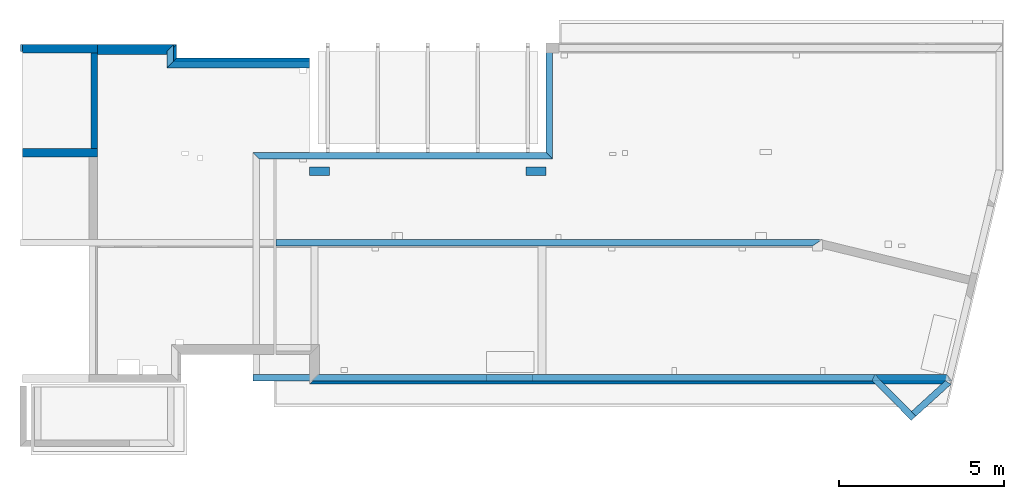
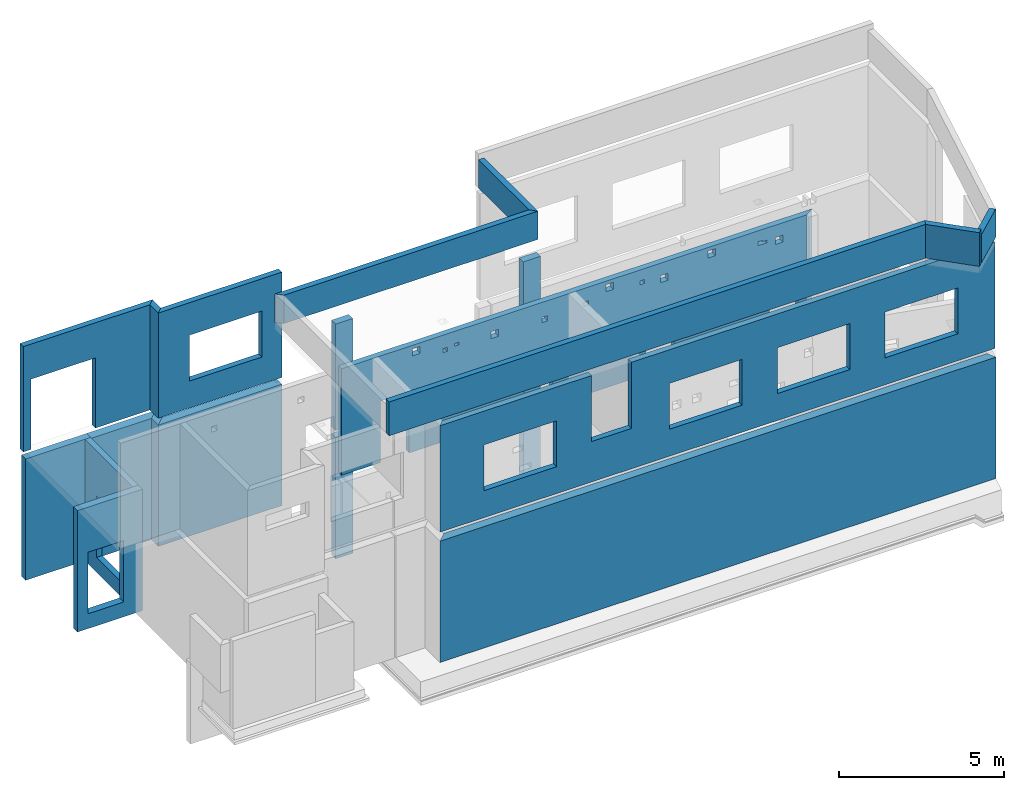
# One storey, part 3 of 7: 21 walls, 28 openings.
"""IFC2X3 building model written with IfcOpenShell, lengths in millimetres."""

from ifc_helpers import new_model, entity, si_unit, converted_unit, derived_unit, money_unit, direction, frame, frame_2d, origin_with_axes, place, context, subcontext, project, spatial, polyline, rectangle, outline, extrude, material, layer, layer_set, layer_usage, type_object, element, save


model = new_model("IFC2X3")

# Units and contexts
model_context = context("Model", 3, precision=1e-05, world=origin_with_axes(), true_north=direction((0.0, 1.0)))
body_context = subcontext(model_context, "Body", "Model", "MODEL_VIEW", scale=1.0)
ifc_project = project(units=[si_unit("LENGTHUNIT", "METRE", prefix="MILLI"), si_unit("AREAUNIT", "SQUARE_METRE"), si_unit("VOLUMEUNIT", "CUBIC_METRE"), si_unit("ABSORBEDDOSEUNIT", "GRAY"), si_unit("AMOUNTOFSUBSTANCEUNIT", "MOLE"), si_unit("DOSEEQUIVALENTUNIT", "SIEVERT"), si_unit("ELECTRICCAPACITANCEUNIT", "FARAD"), si_unit("ELECTRICCHARGEUNIT", "COULOMB"), si_unit("ELECTRICCONDUCTANCEUNIT", "SIEMENS"), si_unit("ELECTRICCURRENTUNIT", "AMPERE"), si_unit("ELECTRICRESISTANCEUNIT", "OHM"), si_unit("ELECTRICVOLTAGEUNIT", "VOLT"), si_unit("ENERGYUNIT", "JOULE"), si_unit("FORCEUNIT", "NEWTON"), si_unit("FREQUENCYUNIT", "HERTZ"), si_unit("ILLUMINANCEUNIT", "LUX"), si_unit("INDUCTANCEUNIT", "HENRY"), si_unit("LUMINOUSFLUXUNIT", "LUMEN"), si_unit("LUMINOUSINTENSITYUNIT", "CANDELA"), si_unit("MAGNETICFLUXDENSITYUNIT", "TESLA"), si_unit("MAGNETICFLUXUNIT", "WEBER"), si_unit("MASSUNIT", "GRAM"), converted_unit("PLANEANGLEUNIT", "degree", entity("IfcReal", 0.0174532925199433), si_unit("PLANEANGLEUNIT", "RADIAN"), dimensions=[0, 0, 0, 0, 0, 0, 0]), si_unit("POWERUNIT", "WATT"), si_unit("PRESSUREUNIT", "PASCAL"), si_unit("RADIOACTIVITYUNIT", "BECQUEREL"), si_unit("SOLIDANGLEUNIT", "STERADIAN"), si_unit("THERMODYNAMICTEMPERATUREUNIT", "KELVIN"), si_unit("TIMEUNIT", "SECOND"), derived_unit("ACCELERATIONUNIT", [(si_unit("LENGTHUNIT", "METRE", prefix="MILLI"), 1), (si_unit("TIMEUNIT", "SECOND"), -2)]), derived_unit("ANGULARVELOCITYUNIT", [(converted_unit("PLANEANGLEUNIT", "degree", entity("IfcReal", 0.0174532925199433), si_unit("PLANEANGLEUNIT", "RADIAN"), dimensions=[0, 0, 0, 0, 0, 0, 0]), 1), (si_unit("TIMEUNIT", "SECOND"), -1)]), derived_unit("CURVATUREUNIT", [(converted_unit("PLANEANGLEUNIT", "degree", entity("IfcReal", 0.0174532925199433), si_unit("PLANEANGLEUNIT", "RADIAN"), dimensions=[0, 0, 0, 0, 0, 0, 0]), 1), (si_unit("LENGTHUNIT", "METRE", prefix="MILLI"), -1)]), derived_unit("DYNAMICVISCOSITYUNIT", [(si_unit("PRESSUREUNIT", "PASCAL"), 1), (si_unit("TIMEUNIT", "SECOND"), 1)]), derived_unit("HEATFLUXDENSITYUNIT", [(si_unit("POWERUNIT", "WATT"), 1), (si_unit("LENGTHUNIT", "METRE", prefix="MILLI"), -2)]), derived_unit("HEATINGVALUEUNIT", [(si_unit("ENERGYUNIT", "JOULE"), 1), (si_unit("MASSUNIT", "GRAM"), -1)]), derived_unit("INTEGERCOUNTRATEUNIT", [(si_unit("TIMEUNIT", "SECOND"), -1)]), derived_unit("IONCONCENTRATIONUNIT", [(si_unit("MASSUNIT", "GRAM"), 1), (si_unit("VOLUMEUNIT", "CUBIC_METRE"), -1)]), derived_unit("ISOTHERMALMOISTURECAPACITYUNIT", [(si_unit("VOLUMEUNIT", "CUBIC_METRE"), 1), (si_unit("MASSUNIT", "GRAM"), -1)]), derived_unit("KINEMATICVISCOSITYUNIT", [(si_unit("AREAUNIT", "SQUARE_METRE"), 1), (si_unit("TIMEUNIT", "SECOND"), -1)]), derived_unit("LINEARFORCEUNIT", [(si_unit("FORCEUNIT", "NEWTON"), 1), (si_unit("LENGTHUNIT", "METRE", prefix="MILLI"), -1)]), derived_unit("LINEARMOMENTUNIT", [(si_unit("FORCEUNIT", "NEWTON"), 1), (si_unit("LENGTHUNIT", "METRE", prefix="MILLI"), -1)]), derived_unit("LINEARSTIFFNESSUNIT", [(si_unit("FORCEUNIT", "NEWTON"), 1), (si_unit("LENGTHUNIT", "METRE", prefix="MILLI"), -1)]), derived_unit("LINEARVELOCITYUNIT", [(si_unit("LENGTHUNIT", "METRE", prefix="MILLI"), 1), (si_unit("TIMEUNIT", "SECOND"), -1)]), derived_unit("LUMINOUSINTENSITYDISTRIBUTIONUNIT", [(si_unit("LUMINOUSINTENSITYUNIT", "CANDELA"), 1), (si_unit("LUMINOUSFLUXUNIT", "LUMEN"), -1)]), derived_unit("MASSDENSITYUNIT", [(si_unit("MASSUNIT", "GRAM"), 1), (si_unit("VOLUMEUNIT", "CUBIC_METRE"), -1)]), derived_unit("MASSFLOWRATEUNIT", [(si_unit("MASSUNIT", "GRAM"), 1), (si_unit("TIMEUNIT", "SECOND"), -1)]), derived_unit("MASSPERLENGTHUNIT", [(si_unit("MASSUNIT", "GRAM"), 1), (si_unit("LENGTHUNIT", "METRE", prefix="MILLI"), -1)]), derived_unit("MODULUSOFELASTICITYUNIT", [(si_unit("FORCEUNIT", "NEWTON"), 1), (si_unit("AREAUNIT", "SQUARE_METRE"), -1)]), derived_unit("MODULUSOFLINEARSUBGRADEREACTIONUNIT", [(si_unit("FORCEUNIT", "NEWTON"), 1), (si_unit("LENGTHUNIT", "METRE", prefix="MILLI"), -2)]), derived_unit("MODULUSOFROTATIONALSUBGRADEREACTIONUNIT", [(si_unit("FORCEUNIT", "NEWTON"), 1), (si_unit("LENGTHUNIT", "METRE", prefix="MILLI"), 1)]), derived_unit("MODULUSOFSUBGRADEREACTIONUNIT", [(si_unit("FORCEUNIT", "NEWTON"), 1), (si_unit("VOLUMEUNIT", "CUBIC_METRE"), -1)]), derived_unit("MOISTUREDIFFUSIVITYUNIT", [(si_unit("VOLUMEUNIT", "CUBIC_METRE"), 1), (si_unit("TIMEUNIT", "SECOND"), -1)]), derived_unit("MOLECULARWEIGHTUNIT", [(si_unit("MASSUNIT", "GRAM"), 1), (si_unit("AMOUNTOFSUBSTANCEUNIT", "MOLE"), -1)]), derived_unit("PLANARFORCEUNIT", [(si_unit("FORCEUNIT", "NEWTON"), 1), (si_unit("LENGTHUNIT", "METRE", prefix="MILLI"), -2)]), derived_unit("ROTATIONALFREQUENCYUNIT", [(si_unit("TIMEUNIT", "SECOND"), -1)]), derived_unit("ROTATIONALMASSUNIT", [(si_unit("MASSUNIT", "GRAM"), 1), (si_unit("LENGTHUNIT", "METRE", prefix="MILLI"), 2)]), derived_unit("ROTATIONALSTIFFNESSUNIT", [(si_unit("FORCEUNIT", "NEWTON"), 1), (si_unit("LENGTHUNIT", "METRE", prefix="MILLI"), 1), (converted_unit("PLANEANGLEUNIT", "degree", entity("IfcReal", 0.0174532925199433), si_unit("PLANEANGLEUNIT", "RADIAN"), dimensions=[0, 0, 0, 0, 0, 0, 0]), -1)]), derived_unit("SECTIONAREAINTEGRALUNIT", [(si_unit("LENGTHUNIT", "METRE", prefix="MILLI"), 5)]), derived_unit("SECTIONMODULUSUNIT", [(si_unit("LENGTHUNIT", "METRE", prefix="MILLI"), 3)]), derived_unit("SHEARMODULUSUNIT", [(si_unit("FORCEUNIT", "NEWTON"), 1), (si_unit("AREAUNIT", "SQUARE_METRE"), -1)]), derived_unit("SOUNDPOWERUNIT", [(si_unit("ENERGYUNIT", "JOULE"), 1), (si_unit("TIMEUNIT", "SECOND"), -1)]), derived_unit("SPECIFICHEATCAPACITYUNIT", [(si_unit("FORCEUNIT", "NEWTON"), 1), (si_unit("MASSUNIT", "GRAM"), -1), (si_unit("THERMODYNAMICTEMPERATUREUNIT", "KELVIN"), -1)]), derived_unit("TEMPERATUREGRADIENTUNIT", [(si_unit("THERMODYNAMICTEMPERATUREUNIT", "KELVIN"), 1), (si_unit("LENGTHUNIT", "METRE", prefix="MILLI"), -1)]), derived_unit("THERMALADMITTANCEUNIT", [(si_unit("POWERUNIT", "WATT"), 1), (si_unit("AREAUNIT", "SQUARE_METRE"), -1), (si_unit("THERMODYNAMICTEMPERATUREUNIT", "KELVIN"), -1)]), derived_unit("THERMALCONDUCTANCEUNIT", [(si_unit("POWERUNIT", "WATT"), 1), (si_unit("LENGTHUNIT", "METRE", prefix="MILLI"), -1), (si_unit("THERMODYNAMICTEMPERATUREUNIT", "KELVIN"), -1)]), derived_unit("THERMALEXPANSIONCOEFFICIENTUNIT", [(si_unit("THERMODYNAMICTEMPERATUREUNIT", "KELVIN"), -1)]), derived_unit("THERMALRESISTANCEUNIT", [(si_unit("AREAUNIT", "SQUARE_METRE"), 1), (si_unit("POWERUNIT", "WATT"), -1)]), derived_unit("THERMALTRANSMITTANCEUNIT", [(si_unit("POWERUNIT", "WATT"), 1), (si_unit("AREAUNIT", "SQUARE_METRE"), -1), (si_unit("THERMODYNAMICTEMPERATUREUNIT", "KELVIN"), -1)]), derived_unit("TORQUEUNIT", [(si_unit("FORCEUNIT", "NEWTON"), 1), (si_unit("LENGTHUNIT", "METRE", prefix="MILLI"), 1)]), derived_unit("VAPORPERMEABILITYUNIT", [(si_unit("MASSUNIT", "GRAM"), 1), (si_unit("TIMEUNIT", "SECOND"), -1)]), derived_unit("VOLUMETRICFLOWRATEUNIT", [(si_unit("VOLUMEUNIT", "CUBIC_METRE"), 1), (si_unit("TIMEUNIT", "SECOND"), -1)]), derived_unit("WARPINGCONSTANTUNIT", [(si_unit("LENGTHUNIT", "METRE", prefix="MILLI"), 6)]), derived_unit("WARPINGMOMENTUNIT", [(si_unit("FORCEUNIT", "NEWTON"), 1), (si_unit("LENGTHUNIT", "METRE", prefix="MILLI"), 2)]), money_unit("USD")], contexts=[model_context])

# Site, building, storey
site_placement = place(None, origin_with_axes())
site = spatial("IfcSite", under=ifc_project, at=site_placement, CompositionType="ELEMENT")
building_placement = place(site_placement, origin_with_axes())
building = spatial("IfcBuilding", under=site, at=building_placement, Name="1", CompositionType="ELEMENT")
storey_placement = place(building_placement, frame((0.0, 0.0, -4900.0), z_axis=(0.0, 0.0, 1.0), x_axis=(1.0, 0.0, 0.0)))
storey = spatial("IfcBuildingStorey", under=building, at=storey_placement, CompositionType="ELEMENT", Elevation=-4900.0)

# Walls
ifc_material = material()
ifc_layer_1 = layer(ifc_material, 250.0, ventilated=False)
ifc_layer_set_1 = layer_set([ifc_layer_1])
ifc_layer_usage_1 = layer_usage(ifc_layer_set_1, "AXIS2", "POSITIVE", 0.0)
wall_type = type_object("IfcWallType", PredefinedType="NOTDEFINED")
for number, where, z_axis, x_axis in (
    (1, (15555.0, 6040.0, 0.0), (0.0, 0.0, 1.0), (1.0, 0.0, 0.0)),
    (2, (8975.0, 6040.0, 0.0), (0.0, 0.0, 1.0), (1.0, 0.0, 0.0)),
):
    element("IfcWallStandardCase", number, at=place(storey_placement, frame(where, z_axis=z_axis, x_axis=x_axis)), inside=storey, type_object=wall_type, material=ifc_layer_usage_1, context=body_context, shape_type="SweptSolid", body=[
        extrude(rectangle(XDim=600.0, YDim=250.0, at=frame_2d((300.0, 125.0), x_axis=(1.0, 0.0))), origin_with_axes(), (0.0, 0.0, 1.0), 4500.0),
    ])
wall_1_placement = place(storey_placement, frame((2530.0, 10010.0, 0.0), z_axis=(0.0, 0.0, 1.0), x_axis=(-1.0, 0.0, 0.0)))
element("IfcWallStandardCase", 3, at=wall_1_placement, inside=storey, type_object=wall_type, material=ifc_layer_usage_1, context=body_context, shape_type="SweptSolid", body=[
    extrude(rectangle(XDim=2280.0, YDim=250.0, at=frame_2d((1140.0, 125.0), x_axis=(1.0, 0.0))), origin_with_axes(), (0.0, 0.0, 1.0), 4500.0),
])

# Wall, opening
wall_2_placement = place(storey_placement, frame((250.0, 6600.0, 0.0), z_axis=(0.0, 0.0, 1.0), x_axis=(1.0, 0.0, 0.0)))
wall_2 = element("IfcWallStandardCase", 4, at=wall_2_placement, inside=storey, type_object=wall_type, material=ifc_layer_usage_1, context=body_context, shape_type="SweptSolid", body=[
    extrude(rectangle(XDim=2280.0, YDim=250.0, at=frame_2d((1140.0, 125.0), x_axis=(1.0, 0.0))), origin_with_axes(), (0.0, 0.0, 1.0), 4500.0),
])
opening_1_placement = place(wall_2_placement, frame((365.0, 0.0, 549.999811), z_axis=(0.0, 0.0, 1.0), x_axis=(1.0, 0.0, 0.0)))
element("IfcOpeningElement", 5, at=opening_1_placement, cuts=wall_2, ObjectType="Opening", context=body_context, shape_type="SweptSolid", body=[
    extrude(rectangle(XDim=2280.0, YDim=1250.0, at=frame_2d((-625.0, 1140.0), x_axis=(0.0, -1.0))), frame((0.0, 0.0, 0.0), z_axis=(0.0, 1.0, 0.0), x_axis=(-1.0, 0.0, 0.0)), (0.0, 0.0, 1.0), 250.0),
])

ifc_layer_2 = layer(ifc_material, 200.0, ventilated=False)
ifc_layer_set_2 = layer_set([ifc_layer_2])
ifc_layer_usage_2 = layer_usage(ifc_layer_set_2, "AXIS2", "POSITIVE", 0.0)
wall_3_placement = place(storey_placement, frame((2330.0, 9760.0, 0.0), z_axis=(0.0, 0.0, 1.0), x_axis=(0.0, -1.0, 0.0)))
wall_3 = element("IfcWallStandardCase", 6, at=wall_3_placement, inside=storey, type_object=wall_type, material=ifc_layer_usage_2, context=body_context, shape_type="SweptSolid", body=[
    extrude(rectangle(XDim=2910.0, YDim=200.0, at=frame_2d((1455.0, 100.0), x_axis=(-1.0, 0.0))), origin_with_axes(), (0.0, 0.0, 1.0), 4500.0),
])
opening_2_placement = place(wall_3_placement, frame((700.0, 0.0, 550.0), z_axis=(0.0, 0.0, 1.0), x_axis=(1.0, 0.0, 0.0)))
element("IfcOpeningElement", 7, at=opening_2_placement, cuts=wall_3, ObjectType="Opening", context=body_context, shape_type="SweptSolid", body=[
    extrude(rectangle(XDim=2280.0, YDim=1500.0, at=frame_2d((-750.0, 1140.0), x_axis=(0.0, -1.0))), frame((0.0, 0.0, 0.0), z_axis=(0.0, 1.0, 0.0), x_axis=(-1.0, 0.0, 0.0)), (0.0, 0.0, 1.0), 200.0),
])

# Walls
ifc_layer_3 = layer(ifc_material, 300.0, ventilated=False)
ifc_layer_set_3 = layer_set([ifc_layer_3])
ifc_layer_usage_3 = layer_usage(ifc_layer_set_3, "AXIS2", "POSITIVE", 0.0)
wall_4_placement = place(storey_placement, frame((8975.0, -300.0, 0.0), z_axis=(0.0, 0.0, 1.0), x_axis=(1.0, 0.0, 0.0)))
element("IfcWallStandardCase", 8, at=wall_4_placement, inside=storey, type_object=wall_type, material=ifc_layer_usage_3, context=body_context, shape_type="SweptSolid", body=[
    extrude(outline(polyline([(19350.128063, 300.0), (300.0, 300.0), (0.0, 0.0), (19483.864598, 0.0), (19350.128063, 300.0)])), origin_with_axes(), (0.0, 0.0, 1.0), 4500.0),
])
wall_5_placement = place(storey_placement, frame((2530.0, 10010.0, 0.0), z_axis=(0.0, 0.0, 1.0), x_axis=(1.0, 0.0, 0.0)))
element("IfcWallStandardCase", 9, at=wall_5_placement, inside=storey, type_object=wall_type, material=ifc_layer_usage_3, context=body_context, shape_type="SweptSolid", body=[
    extrude(outline(polyline([(2410.0, 0.0), (0.0, 0.0), (0.0, -300.0), (2110.0, -300.0), (2410.0, 0.0)])), origin_with_axes(), (0.0, 0.0, 1.0), 4500.0),
])
wall_6_placement = place(storey_placement, frame((4940.0, 10010.0, 0.0), z_axis=(0.0, 0.0, 1.0), x_axis=(0.0, -1.0, 0.0)))
element("IfcWallStandardCase", 10, at=wall_6_placement, inside=storey, type_object=wall_type, material=ifc_layer_usage_3, context=body_context, shape_type="SweptSolid", body=[
    extrude(outline(polyline([(410.0, 0.0), (0.0, 0.0), (300.0, -300.0), (710.0, -300.0), (410.0, 0.0)])), origin_with_axes(), (0.0, 0.0, 1.0), 4500.0),
])
wall_7_placement = place(storey_placement, frame((4940.0, 9600.0, 0.0), z_axis=(0.0, 0.0, 1.0), x_axis=(1.0, 0.0, 0.0)))
element("IfcWallStandardCase", 11, at=wall_7_placement, inside=storey, type_object=wall_type, material=ifc_layer_usage_3, context=body_context, shape_type="SweptSolid", body=[
    extrude(outline(polyline([(0.0, 0.0), (-300.0, -300.0), (4035.0, -300.0), (4035.0, 0.0), (0.0, 0.0)])), origin_with_axes(), (0.0, 0.0, 1.0), 4500.0),
])

# Wall, opening
wall_8_placement = place(storey_placement, frame((200.0, 10010.0, 4750.000002), z_axis=(0.0, 0.0, 1.0), x_axis=(1.0, 0.0, 0.0)))
wall_8 = element("IfcWallStandardCase", 12, at=wall_8_placement, inside=storey, type_object=wall_type, material=ifc_layer_usage_2, context=body_context, shape_type="SweptSolid", body=[
    extrude(outline(polyline([(4640.0, 0.0), (0.0, 0.0), (0.0, -200.0), (4440.0, -200.0), (4640.0, 0.0)])), origin_with_axes(), (0.0, 0.0, 1.0), 3900.0),
])
opening_3_placement = place(wall_8_placement, frame((275.0, -200.0, -2e-06), z_axis=(0.0, 0.0, 1.0), x_axis=(1.0, 0.0, 0.0)))
element("IfcOpeningElement", 13, at=opening_3_placement, cuts=wall_8, ObjectType="Opening", context=body_context, shape_type="SweptSolid", body=[
    extrude(rectangle(XDim=2600.0, YDim=2250.0, at=frame_2d((-1125.0, 1300.0), x_axis=(0.0, -1.0))), frame((0.0, 0.0, 0.0), z_axis=(0.0, 1.0, 0.0), x_axis=(-1.0, 0.0, 0.0)), (0.0, 0.0, 1.0), 200.0),
])

wall_9_placement = place(storey_placement, frame((4640.0, 9300.0, 4750.0), z_axis=(0.0, 0.0, 1.0), x_axis=(1.0, 0.0, 0.0)))
wall_9 = element("IfcWallStandardCase", 14, at=wall_9_placement, inside=storey, type_object=wall_type, material=ifc_layer_usage_2, context=body_context, shape_type="SweptSolid", body=[
    extrude(outline(polyline([(200.0, 200.0), (0.0, 0.0), (4335.0, 0.0), (4335.0, 200.0), (200.0, 200.0)])), origin_with_axes(), (0.0, 0.0, 1.0), 3900.0),
])
opening_4_placement = place(wall_9_placement, frame((1085.0, 0.0, 1000.0), z_axis=(0.0, 0.0, 1.0), x_axis=(1.0, 0.0, 0.0)))
element("IfcOpeningElement", 15, at=opening_4_placement, cuts=wall_9, ObjectType="Opening", context=body_context, shape_type="SweptSolid", body=[
    extrude(rectangle(XDim=1700.0, YDim=2550.0, at=frame_2d((-1275.0, 850.0), x_axis=(0.0, -1.0))), frame((0.0, 0.0, 0.0), z_axis=(0.0, 1.0, 0.0), x_axis=(-1.0, 0.0, 0.0)), (0.0, 0.0, 1.0), 200.0),
])

# Walls
wall_10_placement = place(storey_placement, frame((4840.0, 10010.0, 4750.0), z_axis=(0.0, 0.0, 1.0), x_axis=(0.0, -1.0, 0.0)))
element("IfcWallStandardCase", 16, at=wall_10_placement, inside=storey, type_object=wall_type, material=ifc_layer_usage_2, context=body_context, shape_type="SweptSolid", body=[
    extrude(outline(polyline([(510.0, 0.0), (0.0, 0.0), (200.0, -200.0), (710.0, -200.0), (510.0, 0.0)])), origin_with_axes(), (0.0, 0.0, 1.0), 3900.0),
])
for number, where, z_axis, x_axis in (
    (17, (15555.0, 6040.0, 4750.0), (0.0, 0.0, 1.0), (1.0, 0.0, 0.0)),
    (18, (8975.0, 6040.0, 4750.0), (0.0, 0.0, 1.0), (1.0, 0.0, 0.0)),
):
    element("IfcWallStandardCase", number, at=place(storey_placement, frame(where, z_axis=z_axis, x_axis=x_axis)), inside=storey, type_object=wall_type, material=ifc_layer_usage_1, context=body_context, shape_type="SweptSolid", body=[
        extrude(rectangle(XDim=600.0, YDim=250.0, at=frame_2d((300.0, 125.0), x_axis=(1.0, 0.0))), origin_with_axes(), (0.0, 0.0, 1.0), 3950.0),
    ])

# Wall, openings
wall_11_placement = place(storey_placement, frame((28482.842031, -200.0, 4750.0), z_axis=(0.0, 0.0, 1.0), x_axis=(-1.0, 0.0, 0.0)))
wall_11 = element("IfcWallStandardCase", 19, at=wall_11_placement, inside=storey, type_object=wall_type, material=ifc_layer_usage_2, context=body_context, shape_type="SweptSolid", body=[
    extrude(outline(polyline([(19457.842031, 0.0), (0.0, 0.0), (157.713968, -200.0), (19257.842031, -200.0), (19457.842031, 0.0)])), origin_with_axes(), (0.0, 0.0, 1.0), 3950.0),
])
opening_5_placement = place(wall_11_placement, frame((15367.842031, -200.0, 1000.0), z_axis=(0.0, 0.0, 1.0), x_axis=(1.0, 0.0, 0.0)))
element("IfcOpeningElement", 20, at=opening_5_placement, cuts=wall_11, ObjectType="Opening", context=body_context, shape_type="SweptSolid", body=[
    extrude(rectangle(XDim=1700.0, YDim=2550.0, at=frame_2d((-1275.0, 850.0), x_axis=(0.0, -1.0))), frame((0.0, 0.0, 0.0), z_axis=(0.0, 1.0, 0.0), x_axis=(-1.0, 0.0, 0.0)), (0.0, 0.0, 1.0), 200.0),
])
opening_6_placement = place(wall_11_placement, frame((8857.842031, -200.0, 1000.0), z_axis=(0.0, 0.0, 1.0), x_axis=(1.0, 0.0, 0.0)))
element("IfcOpeningElement", 21, at=opening_6_placement, cuts=wall_11, ObjectType="Opening", context=body_context, shape_type="SweptSolid", body=[
    extrude(rectangle(XDim=1700.0, YDim=2550.0, at=frame_2d((-1275.0, 850.0), x_axis=(0.0, -1.0))), frame((0.0, 0.0, 0.0), z_axis=(0.0, 1.0, 0.0), x_axis=(-1.0, 0.0, 0.0)), (0.0, 0.0, 1.0), 200.0),
])
opening_7_placement = place(wall_11_placement, frame((5077.842031, -200.0, 1000.0), z_axis=(0.0, 0.0, 1.0), x_axis=(1.0, 0.0, 0.0)))
element("IfcOpeningElement", 22, at=opening_7_placement, cuts=wall_11, ObjectType="Opening", context=body_context, shape_type="SweptSolid", body=[
    extrude(rectangle(XDim=1700.0, YDim=2550.0, at=frame_2d((-1275.0, 850.0), x_axis=(0.0, -1.0))), frame((0.0, 0.0, 0.0), z_axis=(0.0, 1.0, 0.0), x_axis=(-1.0, 0.0, 0.0)), (0.0, 0.0, 1.0), 200.0),
])
opening_8_placement = place(wall_11_placement, frame((1297.842031, -200.0, 1000.0), z_axis=(0.0, 0.0, 1.0), x_axis=(1.0, 0.0, 0.0)))
element("IfcOpeningElement", 23, at=opening_8_placement, cuts=wall_11, ObjectType="Opening", context=body_context, shape_type="SweptSolid", body=[
    extrude(rectangle(XDim=1700.0, YDim=2550.0, at=frame_2d((-1275.0, 850.0), x_axis=(0.0, -1.0))), frame((0.0, 0.0, 0.0), z_axis=(0.0, 1.0, 0.0), x_axis=(-1.0, 0.0, 0.0)), (0.0, 0.0, 1.0), 200.0),
])
opening_9_placement = place(wall_11_placement, frame((12737.842031, -200.0, 1500.0), z_axis=(0.0, 0.0, 1.0), x_axis=(1.0, 0.0, 0.0)))
element("IfcOpeningElement", 24, at=opening_9_placement, cuts=wall_11, ObjectType="Opening", context=body_context, shape_type="SweptSolid", body=[
    extrude(rectangle(XDim=2450.0, YDim=1400.0, at=frame_2d((-700.0, 1225.0), x_axis=(0.0, -1.0))), frame((0.0, 0.0, 0.0), z_axis=(0.0, 1.0, 0.0), x_axis=(-1.0, 0.0, 0.0)), (0.0, 0.0, 1.0), 200.0),
])

wall_12_placement = place(storey_placement, frame((7950.0, 3900.0, 4750.0), z_axis=(0.0, 0.0, 1.0), x_axis=(1.0, 0.0, 0.0)))
wall_12 = element("IfcWallStandardCase", 25, at=wall_12_placement, inside=storey, type_object=wall_type, material=ifc_layer_usage_2, context=body_context, shape_type="SweptSolid", body=[
    extrude(outline(polyline([(16605.0, 200.0), (0.0, 200.0), (0.0, 0.0), (16305.0, 0.0), (16605.0, 200.0)])), origin_with_axes(), (0.0, 0.0, 1.0), 3950.0),
])
opening_10_placement = place(wall_12_placement, frame((1365.0, 0.0, 0.0), z_axis=(0.0, 0.0, 1.0), x_axis=(1.0, 0.0, 0.0)))
element("IfcOpeningElement", 26, at=opening_10_placement, cuts=wall_12, ObjectType="Opening", context=body_context, shape_type="SweptSolid", body=[
    extrude(rectangle(XDim=2280.0, YDim=1000.0, at=frame_2d((-500.0, 1140.0), x_axis=(0.0, -1.0))), frame((0.0, 0.0, 0.0), z_axis=(0.0, 1.0, 0.0), x_axis=(-1.0, 0.0, 0.0)), (0.0, 0.0, 1.0), 200.0),
])
opening_11_placement = place(wall_12_placement, frame((6385.0, 0.0, 0.0), z_axis=(0.0, 0.0, 1.0), x_axis=(1.0, 0.0, 0.0)))
element("IfcOpeningElement", 27, at=opening_11_placement, cuts=wall_12, ObjectType="Opening", context=body_context, shape_type="SweptSolid", body=[
    extrude(rectangle(XDim=2280.0, YDim=1000.0, at=frame_2d((-500.0, 1140.0), x_axis=(0.0, -1.0))), frame((0.0, 0.0, 0.0), z_axis=(0.0, 1.0, 0.0), x_axis=(-1.0, 0.0, 0.0)), (0.0, 0.0, 1.0), 200.0),
])
opening_12_placement = place(wall_12_placement, frame((10665.0, 0.0, 0.0), z_axis=(0.0, 0.0, 1.0), x_axis=(1.0, 0.0, 0.0)))
element("IfcOpeningElement", 28, at=opening_12_placement, cuts=wall_12, ObjectType="Opening", context=body_context, shape_type="SweptSolid", body=[
    extrude(rectangle(XDim=2280.0, YDim=1000.0, at=frame_2d((-500.0, 1140.0), x_axis=(0.0, -1.0))), frame((0.0, 0.0, 0.0), z_axis=(0.0, 1.0, 0.0), x_axis=(-1.0, 0.0, 0.0)), (0.0, 0.0, 1.0), 200.0),
])
opening_13_placement = place(wall_12_placement, frame((15005.0, 0.0, 0.0), z_axis=(0.0, 0.0, 1.0), x_axis=(1.0, 0.0, 0.0)))
element("IfcOpeningElement", 29, at=opening_13_placement, cuts=wall_12, ObjectType="Opening", context=body_context, shape_type="SweptSolid", body=[
    extrude(rectangle(XDim=2280.0, YDim=1000.0, at=frame_2d((-500.0, 1140.0), x_axis=(0.0, -1.0))), frame((0.0, 0.0, 0.0), z_axis=(0.0, 1.0, 0.0), x_axis=(-1.0, 0.0, 0.0)), (0.0, 0.0, 1.0), 200.0),
])
opening_14_placement = place(wall_12_placement, frame((7015.0, 0.0, 3200.0), z_axis=(0.0, 0.0, 1.0), x_axis=(1.0, 0.0, 0.0)))
element("IfcOpeningElement", 30, at=opening_14_placement, cuts=wall_12, ObjectType="Opening", context=body_context, shape_type="SweptSolid", body=[
    extrude(rectangle(XDim=200.0, YDim=200.0, at=frame_2d((-100.0, 100.0), x_axis=(0.0, -1.0))), frame((0.0, 0.0, 0.0), z_axis=(0.0, 1.0, 0.0), x_axis=(-1.0, 0.0, 0.0)), (0.0, 0.0, 1.0), 200.0),
])
opening_15_placement = place(wall_12_placement, frame((8504.999928, 0.0, 150.0), z_axis=(0.0, 0.0, 1.0), x_axis=(1.0, 0.0, 0.0)))
element("IfcOpeningElement", 31, at=opening_15_placement, cuts=wall_12, ObjectType="Opening", context=body_context, shape_type="SweptSolid", body=[
    extrude(rectangle(XDim=150.0, YDim=150.0, at=frame_2d((-75.0, 75.0), x_axis=(0.0, -1.0))), frame((0.0, 0.0, 0.0), z_axis=(0.0, 1.0, 0.0), x_axis=(-1.0, 0.0, 0.0)), (0.0, 0.0, 1.0), 200.0),
])
opening_16_placement = place(wall_12_placement, frame((8505.0, 0.0, 3300.0), z_axis=(0.0, 0.0, 1.0), x_axis=(1.0, 0.0, 0.0)))
element("IfcOpeningElement", 32, at=opening_16_placement, cuts=wall_12, ObjectType="Opening", context=body_context, shape_type="SweptSolid", body=[
    extrude(rectangle(XDim=150.0, YDim=150.0, at=frame_2d((-75.0, 75.0), x_axis=(0.0, -1.0))), frame((0.0, 0.0, 0.0), z_axis=(0.0, 1.0, 0.0), x_axis=(-1.0, 0.0, 0.0)), (0.0, 0.0, 1.0), 200.0),
])
opening_17_placement = place(wall_12_placement, frame((9265.0, 0.0, 3560.0), z_axis=(0.0, 0.0, 1.0), x_axis=(1.0, 0.0, 0.0)))
element("IfcOpeningElement", 33, at=opening_17_placement, cuts=wall_12, ObjectType="Opening", context=body_context, shape_type="SweptSolid", body=[
    extrude(rectangle(XDim=260.0, YDim=260.0, at=frame_2d((-130.0, 130.0), x_axis=(0.0, -1.0))), frame((0.0, 0.0, 0.0), z_axis=(0.0, 1.0, 0.0), x_axis=(-1.0, 0.0, 0.0)), (0.0, 0.0, 1.0), 200.0),
])
opening_18_placement = place(wall_12_placement, frame((10465.0, 0.0, 3400.0), z_axis=(0.0, 0.0, 1.0), x_axis=(1.0, 0.0, 0.0)))
element("IfcOpeningElement", 34, at=opening_18_placement, cuts=wall_12, ObjectType="Opening", context=body_context, shape_type="SweptSolid", body=[
    extrude(rectangle(XDim=150.0, YDim=150.0, at=frame_2d((-75.0, 75.0), x_axis=(0.0, -1.0))), frame((0.0, 0.0, 0.0), z_axis=(0.0, 1.0, 0.0), x_axis=(-1.0, 0.0, 0.0)), (0.0, 0.0, 1.0), 200.0),
])
opening_19_placement = place(wall_12_placement, frame((11185.0, 0.0, 3230.0), z_axis=(0.0, 0.0, 1.0), x_axis=(1.0, 0.0, 0.0)))
element("IfcOpeningElement", 35, at=opening_19_placement, cuts=wall_12, ObjectType="Opening", context=body_context, shape_type="SweptSolid", body=[
    extrude(rectangle(XDim=260.0, YDim=260.0, at=frame_2d((-130.0, 130.0), x_axis=(0.0, -1.0))), frame((0.0, 0.0, 0.0), z_axis=(0.0, 1.0, 0.0), x_axis=(-1.0, 0.0, 0.0)), (0.0, 0.0, 1.0), 200.0),
])
opening_20_placement = place(wall_12_placement, frame((12845.0, 0.0, 3560.0), z_axis=(0.0, 0.0, 1.0), x_axis=(1.0, 0.0, 0.0)))
element("IfcOpeningElement", 36, at=opening_20_placement, cuts=wall_12, ObjectType="Opening", context=body_context, shape_type="SweptSolid", body=[
    extrude(rectangle(XDim=260.0, YDim=260.0, at=frame_2d((-130.0, 130.0), x_axis=(0.0, -1.0))), frame((0.0, 0.0, 0.0), z_axis=(0.0, 1.0, 0.0), x_axis=(-1.0, 0.0, 0.0)), (0.0, 0.0, 1.0), 200.0),
])
opening_21_placement = place(wall_12_placement, frame((15205.0, 0.0, 3230.0), z_axis=(0.0, 0.0, 1.0), x_axis=(1.0, 0.0, 0.0)))
element("IfcOpeningElement", 37, at=opening_21_placement, cuts=wall_12, ObjectType="Opening", context=body_context, shape_type="SweptSolid", body=[
    extrude(rectangle(XDim=260.0, YDim=260.0, at=frame_2d((-130.0, 130.0), x_axis=(0.0, -1.0))), frame((0.0, 0.0, 0.0), z_axis=(0.0, 1.0, 0.0), x_axis=(-1.0, 0.0, 0.0)), (0.0, 0.0, 1.0), 200.0),
])
opening_22_placement = place(wall_12_placement, frame((14605.0, 0.0, 150.0), z_axis=(0.0, 0.0, 1.0), x_axis=(1.0, 0.0, 0.0)))
element("IfcOpeningElement", 38, at=opening_22_placement, cuts=wall_12, ObjectType="Opening", context=body_context, shape_type="SweptSolid", body=[
    extrude(rectangle(XDim=150.0, YDim=150.0, at=frame_2d((-75.0, 75.0), x_axis=(0.0, -1.0))), frame((0.0, 0.0, 0.0), z_axis=(0.0, 1.0, 0.0), x_axis=(-1.0, 0.0, 0.0)), (0.0, 0.0, 1.0), 200.0),
])
opening_23_placement = place(wall_12_placement, frame((14605.0, 0.0, 3400.0), z_axis=(0.0, 0.0, 1.0), x_axis=(1.0, 0.0, 0.0)))
element("IfcOpeningElement", 39, at=opening_23_placement, cuts=wall_12, ObjectType="Opening", context=body_context, shape_type="SweptSolid", body=[
    extrude(outline(polyline([(-150.0, 150.0), (0.0, 150.0), (0.0, 0.0), (-300.0, 0.0), (-300.0, 100.0), (-150.0, 100.0), (-150.0, 150.0)])), frame((0.0, 0.0, 0.0), z_axis=(0.0, 1.0, 0.0), x_axis=(-1.0, 0.0, 0.0)), (0.0, 0.0, 1.0), 200.0),
])
opening_24_placement = place(wall_12_placement, frame((2490.0, 0.0, 3560.0), z_axis=(0.0, 0.0, 1.0), x_axis=(1.0, 0.0, 0.0)))
element("IfcOpeningElement", 40, at=opening_24_placement, cuts=wall_12, ObjectType="Opening", context=body_context, shape_type="SweptSolid", body=[
    extrude(rectangle(XDim=260.0, YDim=260.0, at=frame_2d((-130.0, 130.0), x_axis=(0.0, -1.0))), frame((0.0, 0.0, 0.0), z_axis=(0.0, 1.0, 0.0), x_axis=(-1.0, 0.0, 0.0)), (0.0, 0.0, 1.0), 200.0),
])
opening_25_placement = place(wall_12_placement, frame((3555.0, 0.0, 3300.0), z_axis=(0.0, 0.0, 1.0), x_axis=(1.0, 0.0, 0.0)))
element("IfcOpeningElement", 41, at=opening_25_placement, cuts=wall_12, ObjectType="Opening", context=body_context, shape_type="SweptSolid", body=[
    extrude(rectangle(XDim=150.0, YDim=150.0, at=frame_2d((-75.0, 75.0), x_axis=(0.0, -1.0))), frame((0.0, 0.0, 0.0), z_axis=(0.0, 1.0, 0.0), x_axis=(-1.0, 0.0, 0.0)), (0.0, 0.0, 1.0), 200.0),
])
opening_26_placement = place(wall_12_placement, frame((3955.0, 0.0, 3400.0), z_axis=(0.0, 0.0, 1.0), x_axis=(1.0, 0.0, 0.0)))
element("IfcOpeningElement", 42, at=opening_26_placement, cuts=wall_12, ObjectType="Opening", context=body_context, shape_type="SweptSolid", body=[
    extrude(rectangle(XDim=100.0, YDim=150.0, at=frame_2d((-75.0, 50.0), x_axis=(0.0, -1.0))), frame((0.0, 0.0, 0.0), z_axis=(0.0, 1.0, 0.0), x_axis=(-1.0, 0.0, 0.0)), (0.0, 0.0, 1.0), 200.0),
])
opening_27_placement = place(wall_12_placement, frame((3555.0, 0.0, 150.0), z_axis=(0.0, 0.0, 1.0), x_axis=(1.0, 0.0, 0.0)))
element("IfcOpeningElement", 43, at=opening_27_placement, cuts=wall_12, ObjectType="Opening", context=body_context, shape_type="SweptSolid", body=[
    extrude(rectangle(XDim=150.0, YDim=150.0, at=frame_2d((-75.0, 75.0), x_axis=(0.0, -1.0))), frame((0.0, 0.0, 0.0), z_axis=(0.0, 1.0, 0.0), x_axis=(-1.0, 0.0, 0.0)), (0.0, 0.0, 1.0), 200.0),
])
opening_28_placement = place(wall_12_placement, frame((5240.0, 0.0, 3230.0), z_axis=(0.0, 0.0, 1.0), x_axis=(1.0, 0.0, 0.0)))
element("IfcOpeningElement", 44, at=opening_28_placement, cuts=wall_12, ObjectType="Opening", context=body_context, shape_type="SweptSolid", body=[
    extrude(rectangle(XDim=260.0, YDim=260.0, at=frame_2d((-130.0, 130.0), x_axis=(0.0, -1.0))), frame((0.0, 0.0, 0.0), z_axis=(0.0, 1.0, 0.0), x_axis=(-1.0, 0.0, 0.0)), (0.0, 0.0, 1.0), 200.0),
])

# Walls
wall_13_placement = place(storey_placement, frame((27250.0, -1400.0, 8950.0), z_axis=(0.0, 0.0, 1.0), x_axis=(-0.70473793, 0.70946772, 0.0)))
element("IfcWallStandardCase", 45, at=wall_13_placement, inside=storey, type_object=wall_type, material=ifc_layer_usage_2, context=body_context, shape_type="SweptSolid", body=[
    extrude(outline(polyline([(1691.40888, 0.0), (0.0, 0.0), (0.0, -200.0), (1774.643694, -200.0), (1691.40888, 0.0)])), origin_with_axes(), (0.0, 0.0, 1.0), 1250.0),
])
wall_14_placement = place(storey_placement, frame((26058.0, -200.0, 8950.0), z_axis=(0.0, 0.0, 1.0), x_axis=(-1.0, 0.0, 0.0)))
element("IfcWallStandardCase", 46, at=wall_14_placement, inside=storey, type_object=wall_type, material=ifc_layer_usage_2, context=body_context, shape_type="SweptSolid", body=[
    extrude(outline(polyline([(0.0, 0.0), (-83.234813, -200.0), (18808.0, -200.0), (18808.0, 0.0), (0.0, 0.0)])), origin_with_axes(), (0.0, 0.0, 1.0), 1250.0),
])
wall_15_placement = place(storey_placement, frame((27388.41086, -1276.557995, 8950.0), z_axis=(0.0, 0.0, 1.0), x_axis=(0.73876475, 0.67396338, 0.0)))
element("IfcWallStandardCase", 47, at=wall_15_placement, inside=storey, type_object=wall_type, material=ifc_layer_usage_2, context=body_context, shape_type="SweptSolid", body=[
    extrude(outline(polyline([(1387.559069, 200.0), (0.0, 200.0), (0.0, 0.0), (1448.97782, 0.0), (1387.559069, 200.0)])), origin_with_axes(), (0.0, 0.0, 1.0), 1050.0),
])
wall_16_placement = place(storey_placement, frame((7250.0, 6740.0, 8950.0), z_axis=(0.0, 0.0, 1.0), x_axis=(1.0, 0.0, 0.0)))
element("IfcWallStandardCase", 48, at=wall_16_placement, inside=storey, type_object=wall_type, material=ifc_layer_usage_2, context=body_context, shape_type="SweptSolid", body=[
    extrude(outline(polyline([(8905.0, 0.0), (0.0, 0.0), (200.0, -200.0), (9105.0, -200.0), (8905.0, 0.0)])), origin_with_axes(), (0.0, 0.0, 1.0), 1050.0),
])
wall_17_placement = place(storey_placement, frame((16155.0, 6740.0, 8950.0), z_axis=(0.0, 0.0, 1.0), x_axis=(0.0, 1.0, 0.0)))
element("IfcWallStandardCase", 49, at=wall_17_placement, inside=storey, type_object=wall_type, material=ifc_layer_usage_2, context=body_context, shape_type="SweptSolid", body=[
    extrude(outline(polyline([(0.0, 0.0), (-200.0, -200.0), (3070.0, -200.0), (3070.0, 0.0), (0.0, 0.0)])), origin_with_axes(), (0.0, 0.0, 1.0), 1050.0),
])

save(model, "model.ifc")
